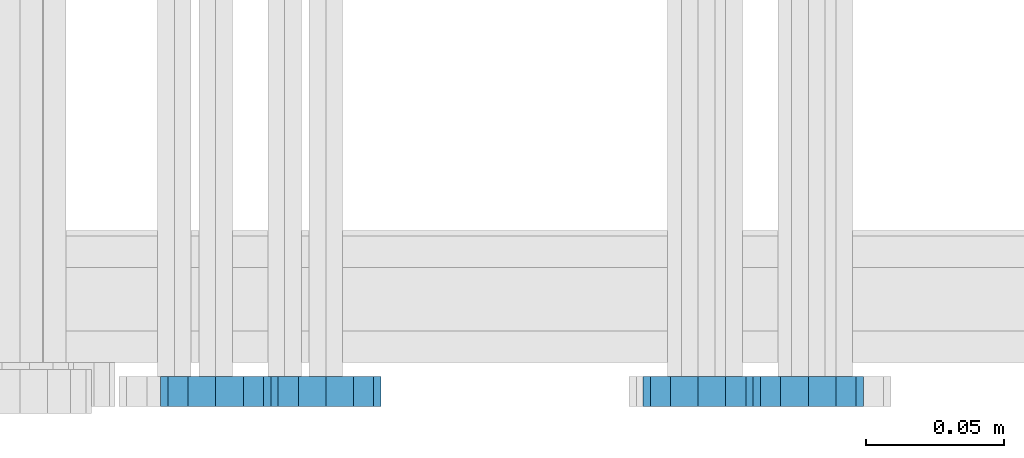
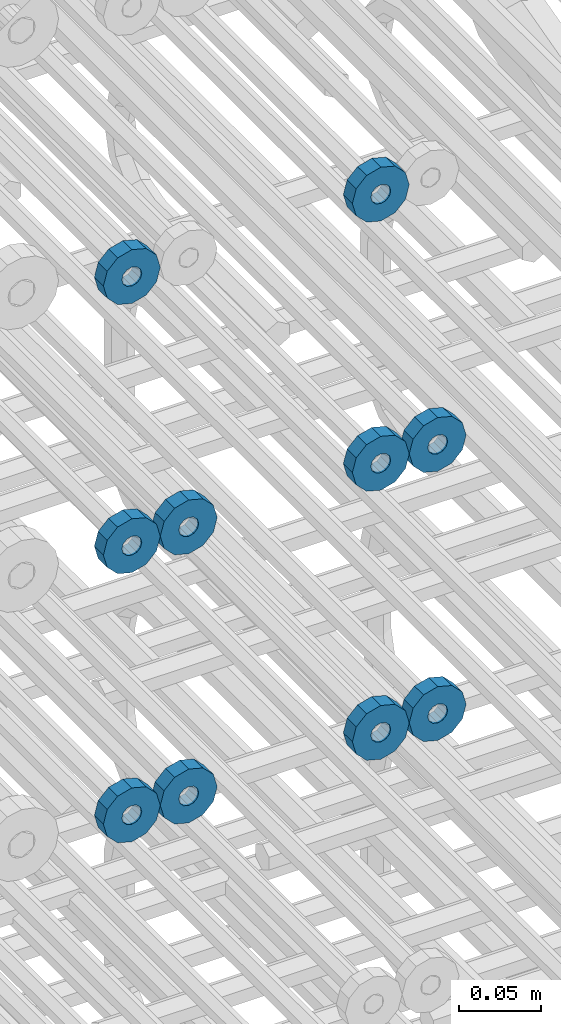
# One storey, part 158 of 177: 10 beams.
"""IFC2X3 building model written with IfcOpenShell, lengths in millimetres."""

from ifc_helpers import new_model, si_unit, frame, origin_with_axes, place, context, subcontext, project, spatial, faceted_brep, material, type_object, element, save


model = new_model("IFC2X3")

# Units and contexts
model_context_1 = context("Model", 3, precision=1e-05, world=origin_with_axes())
model_context_2 = context("Model", 3, precision=1e-05, world=origin_with_axes())
body_context = subcontext(model_context_2, "Body", "Model", "MODEL_VIEW")
ifc_project = project(units=[si_unit("LENGTHUNIT", "METRE", prefix="MILLI"), si_unit("AREAUNIT", "SQUARE_METRE"), si_unit("VOLUMEUNIT", "CUBIC_METRE"), si_unit("MASSUNIT", "GRAM", prefix="KILO"), si_unit("TIMEUNIT", "SECOND"), si_unit("PLANEANGLEUNIT", "RADIAN"), si_unit("SOLIDANGLEUNIT", "STERADIAN"), si_unit("THERMODYNAMICTEMPERATUREUNIT", "DEGREE_CELSIUS"), si_unit("LUMINOUSINTENSITYUNIT", "LUMEN")], contexts=[model_context_1])

# Site, building, storey
site_placement = place(None, origin_with_axes())
site = spatial("IfcSite", under=ifc_project, at=site_placement, CompositionType="ELEMENT")
building_placement = place(site_placement, origin_with_axes())
building = spatial("IfcBuilding", under=site, at=building_placement, Name="Undefined", CompositionType="ELEMENT")
storey_placement = place(building_placement, origin_with_axes())
storey = spatial("IfcBuildingStorey", under=building, at=storey_placement, Name="Undefined", CompositionType="ELEMENT", Elevation=0.0)

# Beams
ifc_material = material(Name="STEEL/Steel_Undefined")
beam_type = type_object("IfcBeamType", PredefinedType="NOTDEFINED")
beam_1_placement = place(storey_placement, frame((2035781.99847313, 6205070.98588032, 21744.9868114202), z_axis=(0.0, 0.0, -1.0), x_axis=(0.0, -1.0, 0.0)))
element("IfcBeam", 1, at=beam_1_placement, inside=storey, type_object=beam_type, material=ifc_material, context=body_context, shape_type="Brep", body=[
    faceted_brep([(-3.63797880709171e-12, -7.0, -2.3283064365387e-10), (-8.62348444298797e-13, -6.06217782649107, 3.5), (10.9999999999964, -6.06217782665044, 3.49999999976717), (10.9999999999964, -7.0, -2.3283064365387e-10), (-3.63797880709171e-12, -3.5, 6.06217782618478), (11.0, -3.5, 6.06217782618478), (-1.72469688859759e-12, 0.0, 7.0), (11.0, 0.0, 6.99999999976717), (-3.63797880709171e-12, 3.5, 6.06217782618478), (11.0, 3.5, 6.06217782618478), (-8.62348444298795e-13, 6.06217782649107, 3.5), (10.9999999999964, 6.06217782665044, 3.49999999976717), (-3.63797880709171e-12, 7.0, -2.3283064365387e-10), (10.9999999999964, 7.0, -2.3283064365387e-10), (8.62348444298797e-13, 6.06217782649107, -3.5), (10.9999999999964, 6.06217782665044, -3.50000000023283), (-3.63797880709171e-12, 3.5, -6.06217782665044), (10.9999999999964, 3.5, -6.06217782665044), (1.72469688859759e-12, -2.72004641033163e-15, -7.0), (10.9999999999964, 0.0, -7.00000000023283), (-3.63797880709171e-12, -3.5, -6.06217782665044), (10.9999999999964, -3.5, -6.06217782665044), (8.62348444298796e-13, -6.06217782649107, -3.5), (10.9999999999964, -6.06217782665044, -3.50000000023283), (0.0, -20.0000000009313, 0.0), (0.0, -17.320508075878, -10.0), (10.9999999999964, -17.320508075878, -10.0000000002328), (10.9999999999964, -20.0, -2.3283064365387e-10), (0.0, -10.0000000009313, -17.3205080756452), (11.0, -10.0, -17.320508075878), (0.0, -1.86264514923096e-09, -19.9999999998836), (10.9999999999964, 0.0, -20.0000000002328), (0.0, 9.99999999906868, -17.3205080755288), (11.0, 10.0, -17.320508075878), (0.0, 17.320508075878, -10.0), (10.9999999999964, 17.320508075878, -10.0000000002328), (0.0, 19.9999999990687, 0.0), (10.9999999999964, 20.0, -2.3283064365387e-10), (0.0, 17.3205080740154, 10.0), (11.0, 17.320508075878, 9.99999999976717), (0.0, 9.99999999906868, 17.3205080757616), (10.9999999999964, 10.0, 17.3205080754124), (0.0, 0.0, 20.0000000001164), (10.9999999999964, 0.0, 19.9999999997672), (0.0, -10.0000000009313, 17.3205080757616), (10.9999999999964, -10.0, 17.3205080754124), (0.0, -17.3205080777407, 10.0000000001164), (11.0, -17.320508075878, 9.99999999976717)], [[[0, 1, 2, 3]], [[1, 4, 5, 2]], [[4, 6, 7, 5]], [[6, 8, 9, 7]], [[8, 10, 11, 9]], [[10, 12, 13, 11]], [[12, 14, 15, 13]], [[14, 16, 17, 15]], [[16, 18, 19, 17]], [[18, 20, 21, 19]], [[20, 22, 23, 21]], [[22, 0, 3, 23]], [[24, 25, 26, 27]], [[25, 28, 29, 26]], [[28, 30, 31, 29]], [[30, 32, 33, 31]], [[32, 34, 35, 33]], [[34, 36, 37, 35]], [[36, 38, 39, 37]], [[38, 40, 41, 39]], [[40, 42, 43, 41]], [[42, 44, 45, 43]], [[44, 46, 47, 45]], [[46, 24, 27, 47]], [[29, 31, 33, 35, 37, 39, 41, 43, 45, 47, 27, 26], [5, 7, 9, 11, 13, 15, 17, 19, 21, 23, 3, 2]], [[46, 44, 42, 40, 38, 36, 34, 32, 30, 28, 25, 24], [22, 20, 18, 16, 14, 12, 10, 8, 6, 4, 1, 0]]]),
])
beam_2_placement = place(storey_placement, frame((2035606.99847313, 6205070.98588032, 21744.9868114254), z_axis=(0.0, 0.0, -1.0), x_axis=(0.0, -1.0, 0.0)))
element("IfcBeam", 2, at=beam_2_placement, inside=storey, type_object=beam_type, material=ifc_material, context=body_context, shape_type="Brep", body=[
    faceted_brep([(-3.63797880709171e-12, -7.0, -2.3283064365387e-10), (-8.62348444298797e-13, -6.06217782649107, 3.5), (10.9999999999964, -6.06217782665044, 3.49999999976717), (10.9999999999964, -7.0, -2.3283064365387e-10), (-3.63797880709171e-12, -3.5, 6.06217782618478), (11.0, -3.5, 6.06217782618478), (-1.72469688859759e-12, 0.0, 7.0), (11.0, 0.0, 6.99999999976717), (-3.63797880709171e-12, 3.5, 6.06217782618478), (11.0, 3.5, 6.06217782618478), (-8.62348444298795e-13, 6.06217782649107, 3.5), (10.9999999999964, 6.06217782665044, 3.49999999976717), (-3.63797880709171e-12, 7.0, -2.3283064365387e-10), (10.9999999999964, 7.0, -2.3283064365387e-10), (8.62348444298797e-13, 6.06217782649107, -3.5), (10.9999999999964, 6.06217782665044, -3.50000000023283), (-3.63797880709171e-12, 3.5, -6.06217782665044), (10.9999999999964, 3.5, -6.06217782665044), (1.72469688859759e-12, -2.72004641033163e-15, -7.0), (10.9999999999964, 0.0, -7.00000000023283), (-3.63797880709171e-12, -3.5, -6.06217782665044), (10.9999999999964, -3.5, -6.06217782665044), (8.62348444298796e-13, -6.06217782649107, -3.5), (10.9999999999964, -6.06217782665044, -3.50000000023283), (0.0, -20.0000000009313, 0.0), (0.0, -17.320508075878, -10.0), (10.9999999999964, -17.320508075878, -10.0000000002328), (10.9999999999964, -20.0, -2.3283064365387e-10), (0.0, -10.0000000009313, -17.3205080756452), (11.0, -10.0, -17.320508075878), (0.0, -1.86264514923096e-09, -19.9999999998836), (10.9999999999964, 0.0, -20.0000000002328), (0.0, 9.99999999906868, -17.3205080755288), (11.0, 10.0, -17.320508075878), (0.0, 17.320508075878, -10.0), (10.9999999999964, 17.320508075878, -10.0000000002328), (0.0, 19.9999999990687, 0.0), (10.9999999999964, 20.0, -2.3283064365387e-10), (0.0, 17.3205080740154, 10.0), (11.0, 17.320508075878, 9.99999999976717), (0.0, 9.99999999906868, 17.3205080757616), (10.9999999999964, 10.0, 17.3205080754124), (0.0, 0.0, 20.0000000001164), (10.9999999999964, 0.0, 19.9999999997672), (0.0, -10.0000000009313, 17.3205080757616), (10.9999999999964, -10.0, 17.3205080754124), (0.0, -17.3205080777407, 10.0000000001164), (11.0, -17.320508075878, 9.99999999976717)], [[[0, 1, 2, 3]], [[1, 4, 5, 2]], [[4, 6, 7, 5]], [[6, 8, 9, 7]], [[8, 10, 11, 9]], [[10, 12, 13, 11]], [[12, 14, 15, 13]], [[14, 16, 17, 15]], [[16, 18, 19, 17]], [[18, 20, 21, 19]], [[20, 22, 23, 21]], [[22, 0, 3, 23]], [[24, 25, 26, 27]], [[25, 28, 29, 26]], [[28, 30, 31, 29]], [[30, 32, 33, 31]], [[32, 34, 35, 33]], [[34, 36, 37, 35]], [[36, 38, 39, 37]], [[38, 40, 41, 39]], [[40, 42, 43, 41]], [[42, 44, 45, 43]], [[44, 46, 47, 45]], [[46, 24, 27, 47]], [[29, 31, 33, 35, 37, 39, 41, 43, 45, 47, 27, 26], [5, 7, 9, 11, 13, 15, 17, 19, 21, 23, 3, 2]], [[46, 44, 42, 40, 38, 36, 34, 32, 30, 28, 25, 24], [22, 20, 18, 16, 14, 12, 10, 8, 6, 4, 1, 0]]]),
])
beam_3_placement = place(storey_placement, frame((2035821.99847313, 6205070.98588032, 21544.9868114202), z_axis=(0.0, 0.0, -1.0), x_axis=(0.0, -1.0, 0.0)))
element("IfcBeam", 3, at=beam_3_placement, inside=storey, type_object=beam_type, material=ifc_material, context=body_context, shape_type="Brep", body=[
    faceted_brep([(-3.63797880709171e-12, -7.0, -2.3283064365387e-10), (-8.62348444298797e-13, -6.06217782649107, 3.5), (10.9999999999964, -6.06217782665044, 3.49999999976717), (10.9999999999964, -7.0, -2.3283064365387e-10), (-3.63797880709171e-12, -3.5, 6.06217782618478), (11.0, -3.5, 6.06217782618478), (-1.72469688859759e-12, 0.0, 7.0), (11.0, 0.0, 6.99999999976717), (-3.63797880709171e-12, 3.5, 6.06217782618478), (11.0, 3.5, 6.06217782618478), (-8.62348444298795e-13, 6.06217782649107, 3.5), (10.9999999999964, 6.06217782665044, 3.49999999976717), (-3.63797880709171e-12, 7.0, -2.3283064365387e-10), (10.9999999999964, 7.0, -2.3283064365387e-10), (8.62348444298797e-13, 6.06217782649107, -3.5), (10.9999999999964, 6.06217782665044, -3.50000000023283), (-3.63797880709171e-12, 3.5, -6.06217782665044), (10.9999999999964, 3.5, -6.06217782665044), (1.72469688859759e-12, -2.72004641033163e-15, -7.0), (10.9999999999964, 0.0, -7.00000000023283), (-3.63797880709171e-12, -3.5, -6.06217782665044), (10.9999999999964, -3.5, -6.06217782665044), (8.62348444298796e-13, -6.06217782649107, -3.5), (10.9999999999964, -6.06217782665044, -3.50000000023283), (0.0, -20.0000000009313, 0.0), (0.0, -17.320508075878, -10.0), (10.9999999999964, -17.320508075878, -10.0000000002328), (10.9999999999964, -20.0, -2.3283064365387e-10), (0.0, -10.0000000009313, -17.3205080756452), (11.0, -10.0, -17.320508075878), (0.0, -1.86264514923096e-09, -19.9999999998836), (10.9999999999964, 0.0, -20.0000000002328), (0.0, 9.99999999906868, -17.3205080755288), (11.0, 10.0, -17.320508075878), (0.0, 17.320508075878, -10.0), (10.9999999999964, 17.320508075878, -10.0000000002328), (0.0, 19.9999999990687, 0.0), (10.9999999999964, 20.0, -2.3283064365387e-10), (0.0, 17.3205080740154, 10.0), (11.0, 17.320508075878, 9.99999999976717), (0.0, 9.99999999906868, 17.3205080757616), (10.9999999999964, 10.0, 17.3205080754124), (0.0, 0.0, 20.0000000001164), (10.9999999999964, 0.0, 19.9999999997672), (0.0, -10.0000000009313, 17.3205080757616), (10.9999999999964, -10.0, 17.3205080754124), (0.0, -17.3205080777407, 10.0000000001164), (11.0, -17.320508075878, 9.99999999976717)], [[[0, 1, 2, 3]], [[1, 4, 5, 2]], [[4, 6, 7, 5]], [[6, 8, 9, 7]], [[8, 10, 11, 9]], [[10, 12, 13, 11]], [[12, 14, 15, 13]], [[14, 16, 17, 15]], [[16, 18, 19, 17]], [[18, 20, 21, 19]], [[20, 22, 23, 21]], [[22, 0, 3, 23]], [[24, 25, 26, 27]], [[25, 28, 29, 26]], [[28, 30, 31, 29]], [[30, 32, 33, 31]], [[32, 34, 35, 33]], [[34, 36, 37, 35]], [[36, 38, 39, 37]], [[38, 40, 41, 39]], [[40, 42, 43, 41]], [[42, 44, 45, 43]], [[44, 46, 47, 45]], [[46, 24, 27, 47]], [[29, 31, 33, 35, 37, 39, 41, 43, 45, 47, 27, 26], [5, 7, 9, 11, 13, 15, 17, 19, 21, 23, 3, 2]], [[46, 44, 42, 40, 38, 36, 34, 32, 30, 28, 25, 24], [22, 20, 18, 16, 14, 12, 10, 8, 6, 4, 1, 0]]]),
])
beam_4_placement = place(storey_placement, frame((2035646.99847313, 6205070.98588032, 21544.9868114254), z_axis=(0.0, 0.0, -1.0), x_axis=(0.0, -1.0, 0.0)))
element("IfcBeam", 4, at=beam_4_placement, inside=storey, type_object=beam_type, material=ifc_material, context=body_context, shape_type="Brep", body=[
    faceted_brep([(-3.63797880709171e-12, -7.0, -2.3283064365387e-10), (-8.62348444298797e-13, -6.06217782649107, 3.5), (10.9999999999964, -6.06217782665044, 3.49999999976717), (10.9999999999964, -7.0, -2.3283064365387e-10), (-3.63797880709171e-12, -3.5, 6.06217782618478), (11.0, -3.5, 6.06217782618478), (-1.72469688859759e-12, 0.0, 7.0), (11.0, 0.0, 6.99999999976717), (-3.63797880709171e-12, 3.5, 6.06217782618478), (11.0, 3.5, 6.06217782618478), (-8.62348444298795e-13, 6.06217782649107, 3.5), (10.9999999999964, 6.06217782665044, 3.49999999976717), (-3.63797880709171e-12, 7.0, -2.3283064365387e-10), (10.9999999999964, 7.0, -2.3283064365387e-10), (8.62348444298797e-13, 6.06217782649107, -3.5), (10.9999999999964, 6.06217782665044, -3.50000000023283), (-3.63797880709171e-12, 3.5, -6.06217782665044), (10.9999999999964, 3.5, -6.06217782665044), (1.72469688859759e-12, -2.72004641033163e-15, -7.0), (10.9999999999964, 0.0, -7.00000000023283), (-3.63797880709171e-12, -3.5, -6.06217782665044), (10.9999999999964, -3.5, -6.06217782665044), (8.62348444298796e-13, -6.06217782649107, -3.5), (10.9999999999964, -6.06217782665044, -3.50000000023283), (0.0, -20.0000000009313, 0.0), (0.0, -17.320508075878, -10.0), (10.9999999999964, -17.320508075878, -10.0000000002328), (10.9999999999964, -20.0, -2.3283064365387e-10), (0.0, -10.0000000009313, -17.3205080756452), (11.0, -10.0, -17.320508075878), (0.0, -1.86264514923096e-09, -19.9999999998836), (10.9999999999964, 0.0, -20.0000000002328), (0.0, 9.99999999906868, -17.3205080755288), (11.0, 10.0, -17.320508075878), (0.0, 17.320508075878, -10.0), (10.9999999999964, 17.320508075878, -10.0000000002328), (0.0, 19.9999999990687, 0.0), (10.9999999999964, 20.0, -2.3283064365387e-10), (0.0, 17.3205080740154, 10.0), (11.0, 17.320508075878, 9.99999999976717), (0.0, 9.99999999906868, 17.3205080757616), (10.9999999999964, 10.0, 17.3205080754124), (0.0, 0.0, 20.0000000001164), (10.9999999999964, 0.0, 19.9999999997672), (0.0, -10.0000000009313, 17.3205080757616), (10.9999999999964, -10.0, 17.3205080754124), (0.0, -17.3205080777407, 10.0000000001164), (11.0, -17.320508075878, 9.99999999976717)], [[[0, 1, 2, 3]], [[1, 4, 5, 2]], [[4, 6, 7, 5]], [[6, 8, 9, 7]], [[8, 10, 11, 9]], [[10, 12, 13, 11]], [[12, 14, 15, 13]], [[14, 16, 17, 15]], [[16, 18, 19, 17]], [[18, 20, 21, 19]], [[20, 22, 23, 21]], [[22, 0, 3, 23]], [[24, 25, 26, 27]], [[25, 28, 29, 26]], [[28, 30, 31, 29]], [[30, 32, 33, 31]], [[32, 34, 35, 33]], [[34, 36, 37, 35]], [[36, 38, 39, 37]], [[38, 40, 41, 39]], [[40, 42, 43, 41]], [[42, 44, 45, 43]], [[44, 46, 47, 45]], [[46, 24, 27, 47]], [[29, 31, 33, 35, 37, 39, 41, 43, 45, 47, 27, 26], [5, 7, 9, 11, 13, 15, 17, 19, 21, 23, 3, 2]], [[46, 44, 42, 40, 38, 36, 34, 32, 30, 28, 25, 24], [22, 20, 18, 16, 14, 12, 10, 8, 6, 4, 1, 0]]]),
])
beam_5_placement = place(storey_placement, frame((2035781.99847313, 6205070.98588032, 21544.9868114202), z_axis=(0.0, 0.0, -1.0), x_axis=(0.0, -1.0, 0.0)))
element("IfcBeam", 5, at=beam_5_placement, inside=storey, type_object=beam_type, material=ifc_material, context=body_context, shape_type="Brep", body=[
    faceted_brep([(-3.63797880709171e-12, -7.0, -2.3283064365387e-10), (-8.62348444298797e-13, -6.06217782649107, 3.5), (10.9999999999964, -6.06217782665044, 3.49999999976717), (10.9999999999964, -7.0, -2.3283064365387e-10), (-3.63797880709171e-12, -3.5, 6.06217782618478), (11.0, -3.5, 6.06217782618478), (-1.72469688859759e-12, 0.0, 7.0), (11.0, 0.0, 6.99999999976717), (-3.63797880709171e-12, 3.5, 6.06217782618478), (11.0, 3.5, 6.06217782618478), (-8.62348444298795e-13, 6.06217782649107, 3.5), (10.9999999999964, 6.06217782665044, 3.49999999976717), (-3.63797880709171e-12, 7.0, -2.3283064365387e-10), (10.9999999999964, 7.0, -2.3283064365387e-10), (8.62348444298797e-13, 6.06217782649107, -3.5), (10.9999999999964, 6.06217782665044, -3.50000000023283), (-3.63797880709171e-12, 3.5, -6.06217782665044), (10.9999999999964, 3.5, -6.06217782665044), (1.72469688859759e-12, -2.72004641033163e-15, -7.0), (10.9999999999964, 0.0, -7.00000000023283), (-3.63797880709171e-12, -3.5, -6.06217782665044), (10.9999999999964, -3.5, -6.06217782665044), (8.62348444298796e-13, -6.06217782649107, -3.5), (10.9999999999964, -6.06217782665044, -3.50000000023283), (0.0, -20.0000000009313, 0.0), (0.0, -17.320508075878, -10.0), (10.9999999999964, -17.320508075878, -10.0000000002328), (10.9999999999964, -20.0, -2.3283064365387e-10), (0.0, -10.0000000009313, -17.3205080756452), (11.0, -10.0, -17.320508075878), (0.0, -1.86264514923096e-09, -19.9999999998836), (10.9999999999964, 0.0, -20.0000000002328), (0.0, 9.99999999906868, -17.3205080755288), (11.0, 10.0, -17.320508075878), (0.0, 17.320508075878, -10.0), (10.9999999999964, 17.320508075878, -10.0000000002328), (0.0, 19.9999999990687, 0.0), (10.9999999999964, 20.0, -2.3283064365387e-10), (0.0, 17.3205080740154, 10.0), (11.0, 17.320508075878, 9.99999999976717), (0.0, 9.99999999906868, 17.3205080757616), (10.9999999999964, 10.0, 17.3205080754124), (0.0, 0.0, 20.0000000001164), (10.9999999999964, 0.0, 19.9999999997672), (0.0, -10.0000000009313, 17.3205080757616), (10.9999999999964, -10.0, 17.3205080754124), (0.0, -17.3205080777407, 10.0000000001164), (11.0, -17.320508075878, 9.99999999976717)], [[[0, 1, 2, 3]], [[1, 4, 5, 2]], [[4, 6, 7, 5]], [[6, 8, 9, 7]], [[8, 10, 11, 9]], [[10, 12, 13, 11]], [[12, 14, 15, 13]], [[14, 16, 17, 15]], [[16, 18, 19, 17]], [[18, 20, 21, 19]], [[20, 22, 23, 21]], [[22, 0, 3, 23]], [[24, 25, 26, 27]], [[25, 28, 29, 26]], [[28, 30, 31, 29]], [[30, 32, 33, 31]], [[32, 34, 35, 33]], [[34, 36, 37, 35]], [[36, 38, 39, 37]], [[38, 40, 41, 39]], [[40, 42, 43, 41]], [[42, 44, 45, 43]], [[44, 46, 47, 45]], [[46, 24, 27, 47]], [[29, 31, 33, 35, 37, 39, 41, 43, 45, 47, 27, 26], [5, 7, 9, 11, 13, 15, 17, 19, 21, 23, 3, 2]], [[46, 44, 42, 40, 38, 36, 34, 32, 30, 28, 25, 24], [22, 20, 18, 16, 14, 12, 10, 8, 6, 4, 1, 0]]]),
])
beam_6_placement = place(storey_placement, frame((2035606.99847313, 6205070.98588032, 21544.9868114254), z_axis=(0.0, 0.0, -1.0), x_axis=(0.0, -1.0, 0.0)))
element("IfcBeam", 6, at=beam_6_placement, inside=storey, type_object=beam_type, material=ifc_material, context=body_context, shape_type="Brep", body=[
    faceted_brep([(-3.63797880709171e-12, -7.0, -2.3283064365387e-10), (-8.62348444298797e-13, -6.06217782649107, 3.5), (10.9999999999964, -6.06217782665044, 3.49999999976717), (10.9999999999964, -7.0, -2.3283064365387e-10), (-3.63797880709171e-12, -3.5, 6.06217782618478), (11.0, -3.5, 6.06217782618478), (-1.72469688859759e-12, 0.0, 7.0), (11.0, 0.0, 6.99999999976717), (-3.63797880709171e-12, 3.5, 6.06217782618478), (11.0, 3.5, 6.06217782618478), (-8.62348444298795e-13, 6.06217782649107, 3.5), (10.9999999999964, 6.06217782665044, 3.49999999976717), (-3.63797880709171e-12, 7.0, -2.3283064365387e-10), (10.9999999999964, 7.0, -2.3283064365387e-10), (8.62348444298797e-13, 6.06217782649107, -3.5), (10.9999999999964, 6.06217782665044, -3.50000000023283), (-3.63797880709171e-12, 3.5, -6.06217782665044), (10.9999999999964, 3.5, -6.06217782665044), (1.72469688859759e-12, -2.72004641033163e-15, -7.0), (10.9999999999964, 0.0, -7.00000000023283), (-3.63797880709171e-12, -3.5, -6.06217782665044), (10.9999999999964, -3.5, -6.06217782665044), (8.62348444298796e-13, -6.06217782649107, -3.5), (10.9999999999964, -6.06217782665044, -3.50000000023283), (0.0, -20.0000000009313, 0.0), (0.0, -17.320508075878, -10.0), (10.9999999999964, -17.320508075878, -10.0000000002328), (10.9999999999964, -20.0, -2.3283064365387e-10), (0.0, -10.0000000009313, -17.3205080756452), (11.0, -10.0, -17.320508075878), (0.0, -1.86264514923096e-09, -19.9999999998836), (10.9999999999964, 0.0, -20.0000000002328), (0.0, 9.99999999906868, -17.3205080755288), (11.0, 10.0, -17.320508075878), (0.0, 17.320508075878, -10.0), (10.9999999999964, 17.320508075878, -10.0000000002328), (0.0, 19.9999999990687, 0.0), (10.9999999999964, 20.0, -2.3283064365387e-10), (0.0, 17.3205080740154, 10.0), (11.0, 17.320508075878, 9.99999999976717), (0.0, 9.99999999906868, 17.3205080757616), (10.9999999999964, 10.0, 17.3205080754124), (0.0, 0.0, 20.0000000001164), (10.9999999999964, 0.0, 19.9999999997672), (0.0, -10.0000000009313, 17.3205080757616), (10.9999999999964, -10.0, 17.3205080754124), (0.0, -17.3205080777407, 10.0000000001164), (11.0, -17.320508075878, 9.99999999976717)], [[[0, 1, 2, 3]], [[1, 4, 5, 2]], [[4, 6, 7, 5]], [[6, 8, 9, 7]], [[8, 10, 11, 9]], [[10, 12, 13, 11]], [[12, 14, 15, 13]], [[14, 16, 17, 15]], [[16, 18, 19, 17]], [[18, 20, 21, 19]], [[20, 22, 23, 21]], [[22, 0, 3, 23]], [[24, 25, 26, 27]], [[25, 28, 29, 26]], [[28, 30, 31, 29]], [[30, 32, 33, 31]], [[32, 34, 35, 33]], [[34, 36, 37, 35]], [[36, 38, 39, 37]], [[38, 40, 41, 39]], [[40, 42, 43, 41]], [[42, 44, 45, 43]], [[44, 46, 47, 45]], [[46, 24, 27, 47]], [[29, 31, 33, 35, 37, 39, 41, 43, 45, 47, 27, 26], [5, 7, 9, 11, 13, 15, 17, 19, 21, 23, 3, 2]], [[46, 44, 42, 40, 38, 36, 34, 32, 30, 28, 25, 24], [22, 20, 18, 16, 14, 12, 10, 8, 6, 4, 1, 0]]]),
])
beam_7_placement = place(storey_placement, frame((2035821.99847313, 6205070.98588033, 21344.9868114202), z_axis=(0.0, 0.0, -1.0), x_axis=(0.0, -1.0, 0.0)))
element("IfcBeam", 7, at=beam_7_placement, inside=storey, type_object=beam_type, material=ifc_material, context=body_context, shape_type="Brep", body=[
    faceted_brep([(-3.63797880709171e-12, -7.0, -2.3283064365387e-10), (-8.62348444298797e-13, -6.06217782649107, 3.5), (10.9999999999964, -6.06217782665044, 3.49999999976717), (10.9999999999964, -7.0, -2.3283064365387e-10), (-3.63797880709171e-12, -3.5, 6.06217782618478), (11.0, -3.5, 6.06217782618478), (-1.72469688859759e-12, 0.0, 7.0), (11.0, 0.0, 6.99999999976717), (-3.63797880709171e-12, 3.5, 6.06217782618478), (11.0, 3.5, 6.06217782618478), (-8.62348444298795e-13, 6.06217782649107, 3.5), (10.9999999999964, 6.06217782665044, 3.49999999976717), (-3.63797880709171e-12, 7.0, -2.3283064365387e-10), (10.9999999999964, 7.0, -2.3283064365387e-10), (8.62348444298797e-13, 6.06217782649107, -3.5), (10.9999999999964, 6.06217782665044, -3.50000000023283), (-3.63797880709171e-12, 3.5, -6.06217782665044), (10.9999999999964, 3.5, -6.06217782665044), (1.72469688859759e-12, -2.72004641033163e-15, -7.0), (10.9999999999964, 0.0, -7.00000000023283), (-3.63797880709171e-12, -3.5, -6.06217782665044), (10.9999999999964, -3.5, -6.06217782665044), (8.62348444298796e-13, -6.06217782649107, -3.5), (10.9999999999964, -6.06217782665044, -3.50000000023283), (0.0, -20.0000000009313, 0.0), (0.0, -17.320508075878, -10.0), (10.9999999999964, -17.320508075878, -10.0000000002328), (10.9999999999964, -20.0, -2.3283064365387e-10), (0.0, -10.0000000009313, -17.3205080756452), (11.0, -10.0, -17.320508075878), (0.0, -1.86264514923096e-09, -19.9999999998836), (10.9999999999964, 0.0, -20.0000000002328), (0.0, 9.99999999906868, -17.3205080755288), (11.0, 10.0, -17.320508075878), (0.0, 17.320508075878, -10.0), (10.9999999999964, 17.320508075878, -10.0000000002328), (0.0, 19.9999999990687, 0.0), (10.9999999999964, 20.0, -2.3283064365387e-10), (0.0, 17.3205080740154, 10.0), (11.0, 17.320508075878, 9.99999999976717), (0.0, 9.99999999906868, 17.3205080757616), (10.9999999999964, 10.0, 17.3205080754124), (0.0, 0.0, 20.0000000001164), (10.9999999999964, 0.0, 19.9999999997672), (0.0, -10.0000000009313, 17.3205080757616), (10.9999999999964, -10.0, 17.3205080754124), (0.0, -17.3205080777407, 10.0000000001164), (11.0, -17.320508075878, 9.99999999976717)], [[[0, 1, 2, 3]], [[1, 4, 5, 2]], [[4, 6, 7, 5]], [[6, 8, 9, 7]], [[8, 10, 11, 9]], [[10, 12, 13, 11]], [[12, 14, 15, 13]], [[14, 16, 17, 15]], [[16, 18, 19, 17]], [[18, 20, 21, 19]], [[20, 22, 23, 21]], [[22, 0, 3, 23]], [[24, 25, 26, 27]], [[25, 28, 29, 26]], [[28, 30, 31, 29]], [[30, 32, 33, 31]], [[32, 34, 35, 33]], [[34, 36, 37, 35]], [[36, 38, 39, 37]], [[38, 40, 41, 39]], [[40, 42, 43, 41]], [[42, 44, 45, 43]], [[44, 46, 47, 45]], [[46, 24, 27, 47]], [[29, 31, 33, 35, 37, 39, 41, 43, 45, 47, 27, 26], [5, 7, 9, 11, 13, 15, 17, 19, 21, 23, 3, 2]], [[46, 44, 42, 40, 38, 36, 34, 32, 30, 28, 25, 24], [22, 20, 18, 16, 14, 12, 10, 8, 6, 4, 1, 0]]]),
])
beam_8_placement = place(storey_placement, frame((2035646.99847313, 6205070.98588033, 21344.9868114254), z_axis=(0.0, 0.0, -1.0), x_axis=(0.0, -1.0, 0.0)))
element("IfcBeam", 8, at=beam_8_placement, inside=storey, type_object=beam_type, material=ifc_material, context=body_context, shape_type="Brep", body=[
    faceted_brep([(-3.63797880709171e-12, -7.0, -2.3283064365387e-10), (-8.62348444298797e-13, -6.06217782649107, 3.5), (10.9999999999964, -6.06217782665044, 3.49999999976717), (10.9999999999964, -7.0, -2.3283064365387e-10), (-3.63797880709171e-12, -3.5, 6.06217782618478), (11.0, -3.5, 6.06217782618478), (-1.72469688859759e-12, 0.0, 7.0), (11.0, 0.0, 6.99999999976717), (-3.63797880709171e-12, 3.5, 6.06217782618478), (11.0, 3.5, 6.06217782618478), (-8.62348444298795e-13, 6.06217782649107, 3.5), (10.9999999999964, 6.06217782665044, 3.49999999976717), (-3.63797880709171e-12, 7.0, -2.3283064365387e-10), (10.9999999999964, 7.0, -2.3283064365387e-10), (8.62348444298797e-13, 6.06217782649107, -3.5), (10.9999999999964, 6.06217782665044, -3.50000000023283), (-3.63797880709171e-12, 3.5, -6.06217782665044), (10.9999999999964, 3.5, -6.06217782665044), (1.72469688859759e-12, -2.72004641033163e-15, -7.0), (10.9999999999964, 0.0, -7.00000000023283), (-3.63797880709171e-12, -3.5, -6.06217782665044), (10.9999999999964, -3.5, -6.06217782665044), (8.62348444298796e-13, -6.06217782649107, -3.5), (10.9999999999964, -6.06217782665044, -3.50000000023283), (0.0, -20.0000000009313, 0.0), (0.0, -17.320508075878, -10.0), (10.9999999999964, -17.320508075878, -10.0000000002328), (10.9999999999964, -20.0, -2.3283064365387e-10), (0.0, -10.0000000009313, -17.3205080756452), (11.0, -10.0, -17.320508075878), (0.0, -1.86264514923096e-09, -19.9999999998836), (10.9999999999964, 0.0, -20.0000000002328), (0.0, 9.99999999906868, -17.3205080755288), (11.0, 10.0, -17.320508075878), (0.0, 17.320508075878, -10.0), (10.9999999999964, 17.320508075878, -10.0000000002328), (0.0, 19.9999999990687, 0.0), (10.9999999999964, 20.0, -2.3283064365387e-10), (0.0, 17.3205080740154, 10.0), (11.0, 17.320508075878, 9.99999999976717), (0.0, 9.99999999906868, 17.3205080757616), (10.9999999999964, 10.0, 17.3205080754124), (0.0, 0.0, 20.0000000001164), (10.9999999999964, 0.0, 19.9999999997672), (0.0, -10.0000000009313, 17.3205080757616), (10.9999999999964, -10.0, 17.3205080754124), (0.0, -17.3205080777407, 10.0000000001164), (11.0, -17.320508075878, 9.99999999976717)], [[[0, 1, 2, 3]], [[1, 4, 5, 2]], [[4, 6, 7, 5]], [[6, 8, 9, 7]], [[8, 10, 11, 9]], [[10, 12, 13, 11]], [[12, 14, 15, 13]], [[14, 16, 17, 15]], [[16, 18, 19, 17]], [[18, 20, 21, 19]], [[20, 22, 23, 21]], [[22, 0, 3, 23]], [[24, 25, 26, 27]], [[25, 28, 29, 26]], [[28, 30, 31, 29]], [[30, 32, 33, 31]], [[32, 34, 35, 33]], [[34, 36, 37, 35]], [[36, 38, 39, 37]], [[38, 40, 41, 39]], [[40, 42, 43, 41]], [[42, 44, 45, 43]], [[44, 46, 47, 45]], [[46, 24, 27, 47]], [[29, 31, 33, 35, 37, 39, 41, 43, 45, 47, 27, 26], [5, 7, 9, 11, 13, 15, 17, 19, 21, 23, 3, 2]], [[46, 44, 42, 40, 38, 36, 34, 32, 30, 28, 25, 24], [22, 20, 18, 16, 14, 12, 10, 8, 6, 4, 1, 0]]]),
])
beam_9_placement = place(storey_placement, frame((2035781.99847313, 6205070.98588033, 21344.9868114202), z_axis=(0.0, 0.0, -1.0), x_axis=(0.0, -1.0, 0.0)))
element("IfcBeam", 9, at=beam_9_placement, inside=storey, type_object=beam_type, material=ifc_material, context=body_context, shape_type="Brep", body=[
    faceted_brep([(-3.63797880709171e-12, -7.0, -2.3283064365387e-10), (-8.62348444298797e-13, -6.06217782649107, 3.5), (10.9999999999964, -6.06217782665044, 3.49999999976717), (10.9999999999964, -7.0, -2.3283064365387e-10), (-3.63797880709171e-12, -3.5, 6.06217782618478), (11.0, -3.5, 6.06217782618478), (-1.72469688859759e-12, 0.0, 7.0), (11.0, 0.0, 6.99999999976717), (-3.63797880709171e-12, 3.5, 6.06217782618478), (11.0, 3.5, 6.06217782618478), (-8.62348444298795e-13, 6.06217782649107, 3.5), (10.9999999999964, 6.06217782665044, 3.49999999976717), (-3.63797880709171e-12, 7.0, -2.3283064365387e-10), (10.9999999999964, 7.0, -2.3283064365387e-10), (8.62348444298797e-13, 6.06217782649107, -3.5), (10.9999999999964, 6.06217782665044, -3.50000000023283), (-3.63797880709171e-12, 3.5, -6.06217782665044), (10.9999999999964, 3.5, -6.06217782665044), (1.72469688859759e-12, -2.72004641033163e-15, -7.0), (10.9999999999964, 0.0, -7.00000000023283), (-3.63797880709171e-12, -3.5, -6.06217782665044), (10.9999999999964, -3.5, -6.06217782665044), (8.62348444298796e-13, -6.06217782649107, -3.5), (10.9999999999964, -6.06217782665044, -3.50000000023283), (0.0, -20.0000000009313, 0.0), (0.0, -17.320508075878, -10.0), (10.9999999999964, -17.320508075878, -10.0000000002328), (10.9999999999964, -20.0, -2.3283064365387e-10), (0.0, -10.0000000009313, -17.3205080756452), (11.0, -10.0, -17.320508075878), (0.0, -1.86264514923096e-09, -19.9999999998836), (10.9999999999964, 0.0, -20.0000000002328), (0.0, 9.99999999906868, -17.3205080755288), (11.0, 10.0, -17.320508075878), (0.0, 17.320508075878, -10.0), (10.9999999999964, 17.320508075878, -10.0000000002328), (0.0, 19.9999999990687, 0.0), (10.9999999999964, 20.0, -2.3283064365387e-10), (0.0, 17.3205080740154, 10.0), (11.0, 17.320508075878, 9.99999999976717), (0.0, 9.99999999906868, 17.3205080757616), (10.9999999999964, 10.0, 17.3205080754124), (0.0, 0.0, 20.0000000001164), (10.9999999999964, 0.0, 19.9999999997672), (0.0, -10.0000000009313, 17.3205080757616), (10.9999999999964, -10.0, 17.3205080754124), (0.0, -17.3205080777407, 10.0000000001164), (11.0, -17.320508075878, 9.99999999976717)], [[[0, 1, 2, 3]], [[1, 4, 5, 2]], [[4, 6, 7, 5]], [[6, 8, 9, 7]], [[8, 10, 11, 9]], [[10, 12, 13, 11]], [[12, 14, 15, 13]], [[14, 16, 17, 15]], [[16, 18, 19, 17]], [[18, 20, 21, 19]], [[20, 22, 23, 21]], [[22, 0, 3, 23]], [[24, 25, 26, 27]], [[25, 28, 29, 26]], [[28, 30, 31, 29]], [[30, 32, 33, 31]], [[32, 34, 35, 33]], [[34, 36, 37, 35]], [[36, 38, 39, 37]], [[38, 40, 41, 39]], [[40, 42, 43, 41]], [[42, 44, 45, 43]], [[44, 46, 47, 45]], [[46, 24, 27, 47]], [[29, 31, 33, 35, 37, 39, 41, 43, 45, 47, 27, 26], [5, 7, 9, 11, 13, 15, 17, 19, 21, 23, 3, 2]], [[46, 44, 42, 40, 38, 36, 34, 32, 30, 28, 25, 24], [22, 20, 18, 16, 14, 12, 10, 8, 6, 4, 1, 0]]]),
])
beam_10_placement = place(storey_placement, frame((2035606.99847313, 6205070.98588033, 21344.9868114254), z_axis=(0.0, 0.0, -1.0), x_axis=(0.0, -1.0, 0.0)))
element("IfcBeam", 10, at=beam_10_placement, inside=storey, type_object=beam_type, material=ifc_material, context=body_context, shape_type="Brep", body=[
    faceted_brep([(-3.63797880709171e-12, -7.0, -2.3283064365387e-10), (-8.62348444298797e-13, -6.06217782649107, 3.5), (10.9999999999964, -6.06217782665044, 3.49999999976717), (10.9999999999964, -7.0, -2.3283064365387e-10), (-3.63797880709171e-12, -3.5, 6.06217782618478), (11.0, -3.5, 6.06217782618478), (-1.72469688859759e-12, 0.0, 7.0), (11.0, 0.0, 6.99999999976717), (-3.63797880709171e-12, 3.5, 6.06217782618478), (11.0, 3.5, 6.06217782618478), (-8.62348444298795e-13, 6.06217782649107, 3.5), (10.9999999999964, 6.06217782665044, 3.49999999976717), (-3.63797880709171e-12, 7.0, -2.3283064365387e-10), (10.9999999999964, 7.0, -2.3283064365387e-10), (8.62348444298797e-13, 6.06217782649107, -3.5), (10.9999999999964, 6.06217782665044, -3.50000000023283), (-3.63797880709171e-12, 3.5, -6.06217782665044), (10.9999999999964, 3.5, -6.06217782665044), (1.72469688859759e-12, -2.72004641033163e-15, -7.0), (10.9999999999964, 0.0, -7.00000000023283), (-3.63797880709171e-12, -3.5, -6.06217782665044), (10.9999999999964, -3.5, -6.06217782665044), (8.62348444298796e-13, -6.06217782649107, -3.5), (10.9999999999964, -6.06217782665044, -3.50000000023283), (0.0, -20.0000000009313, 0.0), (0.0, -17.320508075878, -10.0), (10.9999999999964, -17.320508075878, -10.0000000002328), (10.9999999999964, -20.0, -2.3283064365387e-10), (0.0, -10.0000000009313, -17.3205080756452), (11.0, -10.0, -17.320508075878), (0.0, -1.86264514923096e-09, -19.9999999998836), (10.9999999999964, 0.0, -20.0000000002328), (0.0, 9.99999999906868, -17.3205080755288), (11.0, 10.0, -17.320508075878), (0.0, 17.320508075878, -10.0), (10.9999999999964, 17.320508075878, -10.0000000002328), (0.0, 19.9999999990687, 0.0), (10.9999999999964, 20.0, -2.3283064365387e-10), (0.0, 17.3205080740154, 10.0), (11.0, 17.320508075878, 9.99999999976717), (0.0, 9.99999999906868, 17.3205080757616), (10.9999999999964, 10.0, 17.3205080754124), (0.0, 0.0, 20.0000000001164), (10.9999999999964, 0.0, 19.9999999997672), (0.0, -10.0000000009313, 17.3205080757616), (10.9999999999964, -10.0, 17.3205080754124), (0.0, -17.3205080777407, 10.0000000001164), (11.0, -17.320508075878, 9.99999999976717)], [[[0, 1, 2, 3]], [[1, 4, 5, 2]], [[4, 6, 7, 5]], [[6, 8, 9, 7]], [[8, 10, 11, 9]], [[10, 12, 13, 11]], [[12, 14, 15, 13]], [[14, 16, 17, 15]], [[16, 18, 19, 17]], [[18, 20, 21, 19]], [[20, 22, 23, 21]], [[22, 0, 3, 23]], [[24, 25, 26, 27]], [[25, 28, 29, 26]], [[28, 30, 31, 29]], [[30, 32, 33, 31]], [[32, 34, 35, 33]], [[34, 36, 37, 35]], [[36, 38, 39, 37]], [[38, 40, 41, 39]], [[40, 42, 43, 41]], [[42, 44, 45, 43]], [[44, 46, 47, 45]], [[46, 24, 27, 47]], [[29, 31, 33, 35, 37, 39, 41, 43, 45, 47, 27, 26], [5, 7, 9, 11, 13, 15, 17, 19, 21, 23, 3, 2]], [[46, 44, 42, 40, 38, 36, 34, 32, 30, 28, 25, 24], [22, 20, 18, 16, 14, 12, 10, 8, 6, 4, 1, 0]]]),
])

save(model, "model.ifc")
